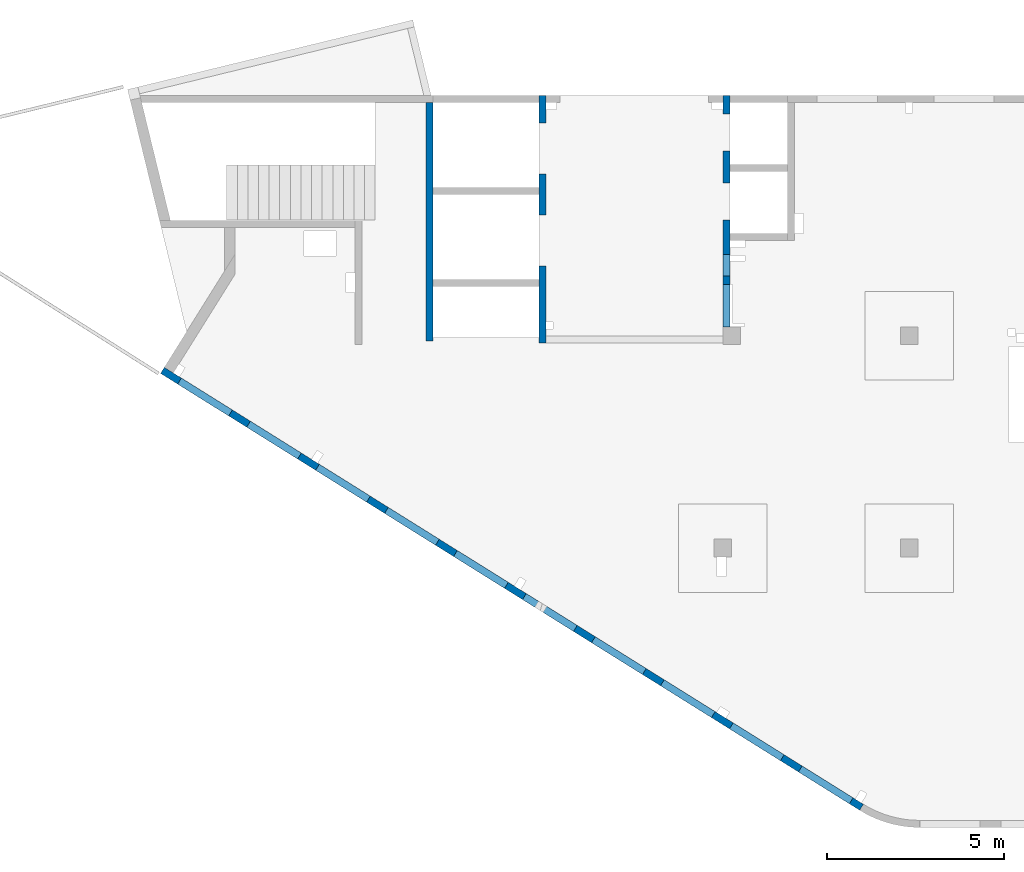
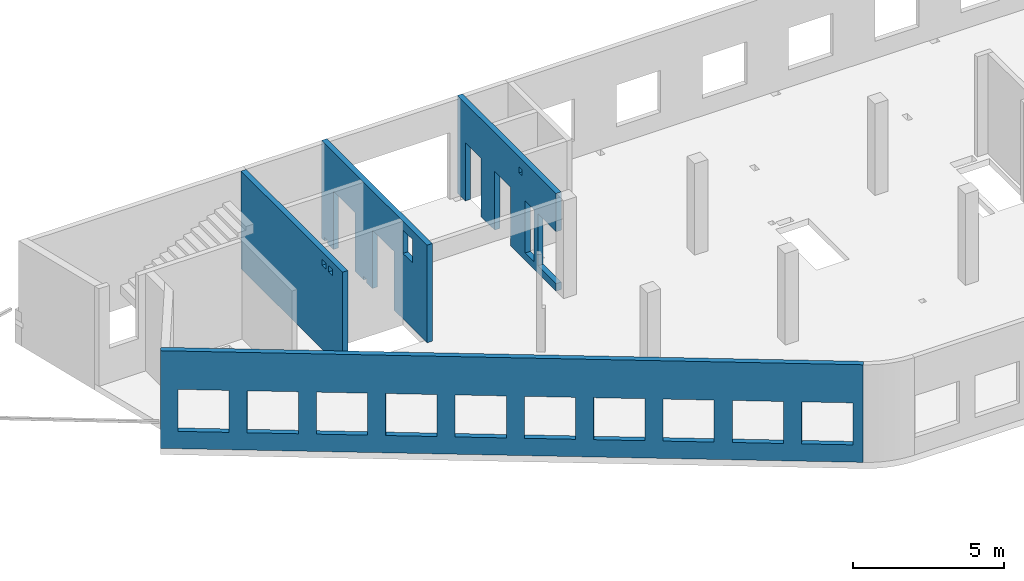
# One storey, part 5 of 7: 4 walls, 22 openings.
"""IFC4 building model written with IfcOpenShell, lengths in millimetres."""

from ifc_helpers import new_model, entity, si_unit, converted_unit, derived_unit, direction, frame, origin, place, context, subcontext, project, spatial, indexed_curve, outline, extrude, polygons, material, type_object, element, save


model = new_model("IFC4")

# Units and contexts
model_context = context("Model", 3, precision=0.01, world=origin(), true_north=direction((6.12303176911189e-17, 1.0)))
plan_context = context("Plan", 3, precision=0.01, world=origin(), true_north=direction((6.12303176911189e-17, 1.0)))
body_context = subcontext(model_context, "Body", "Model", "MODEL_VIEW")
ifc_project = project(units=[si_unit("LENGTHUNIT", "METRE", prefix="MILLI"), si_unit("AREAUNIT", "SQUARE_METRE"), si_unit("VOLUMEUNIT", "CUBIC_METRE"), converted_unit("PLANEANGLEUNIT", "DEGREE", entity("IfcRatioMeasure", 0.0174532925199433), si_unit("PLANEANGLEUNIT", "RADIAN"), dimensions=[0, 0, 0, 0, 0, 0, 0]), si_unit("MASSUNIT", "GRAM", prefix="KILO"), derived_unit("MASSDENSITYUNIT", [(si_unit("MASSUNIT", "GRAM", prefix="KILO"), 1), (si_unit("LENGTHUNIT", "METRE"), -3)]), derived_unit("MOMENTOFINERTIAUNIT", [(si_unit("LENGTHUNIT", "METRE"), 4)]), si_unit("TIMEUNIT", "SECOND"), si_unit("FREQUENCYUNIT", "HERTZ"), si_unit("THERMODYNAMICTEMPERATUREUNIT", "DEGREE_CELSIUS"), derived_unit("THERMALTRANSMITTANCEUNIT", [(si_unit("MASSUNIT", "GRAM", prefix="KILO"), 1), (si_unit("THERMODYNAMICTEMPERATUREUNIT", "KELVIN"), -1), (si_unit("TIMEUNIT", "SECOND"), -3)]), derived_unit("VOLUMETRICFLOWRATEUNIT", [(si_unit("LENGTHUNIT", "METRE"), 3), (si_unit("TIMEUNIT", "SECOND"), -1)]), derived_unit("MASSFLOWRATEUNIT", [(si_unit("MASSUNIT", "GRAM", prefix="KILO"), 1), (si_unit("TIMEUNIT", "SECOND"), -1)]), derived_unit("ROTATIONALFREQUENCYUNIT", [(si_unit("TIMEUNIT", "SECOND"), -1)]), si_unit("ELECTRICCURRENTUNIT", "AMPERE"), si_unit("ELECTRICVOLTAGEUNIT", "VOLT"), si_unit("POWERUNIT", "WATT"), si_unit("FORCEUNIT", "NEWTON", prefix="KILO"), si_unit("ILLUMINANCEUNIT", "LUX"), si_unit("LUMINOUSFLUXUNIT", "LUMEN"), si_unit("LUMINOUSINTENSITYUNIT", "CANDELA"), derived_unit("USERDEFINED", [(si_unit("MASSUNIT", "GRAM", prefix="KILO"), -1), (si_unit("LENGTHUNIT", "METRE"), -2), (si_unit("TIMEUNIT", "SECOND"), 3), (si_unit("LUMINOUSFLUXUNIT", "LUMEN"), 1)]), derived_unit("LINEARVELOCITYUNIT", [(si_unit("LENGTHUNIT", "METRE"), 1), (si_unit("TIMEUNIT", "SECOND"), -1)]), si_unit("PRESSUREUNIT", "PASCAL"), derived_unit("USERDEFINED", [(si_unit("LENGTHUNIT", "METRE"), -2), (si_unit("MASSUNIT", "GRAM", prefix="KILO"), 1), (si_unit("TIMEUNIT", "SECOND"), -2)]), derived_unit("LINEARFORCEUNIT", [(si_unit("MASSUNIT", "GRAM", prefix="KILO"), 1), (si_unit("LENGTHUNIT", "METRE"), 1), (si_unit("TIMEUNIT", "SECOND"), -2), (si_unit("LENGTHUNIT", "METRE"), -1)]), derived_unit("PLANARFORCEUNIT", [(si_unit("MASSUNIT", "GRAM", prefix="KILO"), 1), (si_unit("LENGTHUNIT", "METRE"), 1), (si_unit("TIMEUNIT", "SECOND"), -2), (si_unit("LENGTHUNIT", "METRE"), -2)])], contexts=[model_context, plan_context])

# Site, building, storey
site_placement = place(None, origin())
site = spatial("IfcSite", under=ifc_project, at=site_placement, CompositionType="ELEMENT")
building_placement = place(site_placement, origin())
building = spatial("IfcBuilding", under=site, at=building_placement, CompositionType="ELEMENT")
storey_placement = place(building_placement, frame((0.0, 0.0, 24000.0)))
storey = spatial("IfcBuildingStorey", under=building, at=storey_placement, Name="07", CompositionType="ELEMENT", Elevation=24000.0)

# Wall, openings
ifc_material = material()
wall_type = type_object("IfcWallType", Name=":ADSK_ 25_200", PredefinedType="STANDARD")
wall_1_placement = place(storey_placement, frame((19823.51, 370.44, -150.0), z_axis=(0.0, 0.0, 1.0), x_axis=(-0.848052743777574, 0.529911826412025, 0.0)))
wall_1 = element("IfcWall", 1, at=wall_1_placement, inside=storey, type_object=wall_type, material=ifc_material, Name=":ADSK_ 25_200", ObjectType=":ADSK_ 25_200", PredefinedType="NOTDEFINED", context=body_context, shape_type="Tessellation", body=[
    polygons([(-1.45510270499472e-12, -99.9999999999999, 0.0), (23013.0035862376, -99.9999999999989, 0.0), (23313.0035862376, -99.9999999999989, 0.0), (23313.0035862376, -99.9999999999989, 3950.0), (23013.0035862376, -99.9999999999989, 3950.0), (18403.0035862376, -99.9999999999989, 3950.0), (18103.0035862376, -100.0, 3950.0), (-1.45510270499472e-12, -99.9999999999999, 3950.0), (343.003167803934, -99.9999999999988, 2400.0), (2043.00316780393, -99.9999999999981, 2400.0), (2043.00316780393, -99.9999999999981, 700.00000000001), (343.003167803934, -99.9999999999988, 700.00000000001), (2643.00316780394, -99.9999999999995, 2400.0), (4343.00316780394, -99.9999999999992, 2400.0), (4343.00316780394, -99.9999999999992, 700.00000000001), (2643.00316780394, -99.9999999999995, 700.00000000001), (4943.00316780394, -100.0, 2400.0), (6643.00316780394, -99.9999999999984, 2400.0), (6643.00316780394, -99.9999999999984, 700.00000000001), (4943.00316780394, -100.0, 700.00000000001), (7243.00316780395, -99.9999999999984, 2400.0), (8943.00316780395, -100.0, 2400.0), (8943.00316780395, -100.0, 700.00000000001), (7243.00316780395, -99.9999999999984, 700.00000000001), (9543.00316780396, -100.0, 2400.0), (11243.003167804, -99.9999999999989, 2400.0), (11243.003167804, -99.9999999999989, 700.00000000001), (9543.00316780396, -100.0, 700.00000000001), (11843.003167804, -100.0, 2400.0), (13543.003167804, -100.0, 2400.0), (13543.003167804, -100.0, 700.00000000001), (11843.003167804, -100.0, 700.00000000001), (14143.003167804, -100.0, 2400.0), (15843.003167804, -100.0, 2400.0), (15843.003167804, -100.0, 700.00000000001), (14143.003167804, -100.0, 700.00000000001), (16443.003167804, -99.9999999999989, 2400.0), (18143.003167804, -99.9999999999989, 2400.0), (18143.003167804, -99.9999999999989, 700.00000000001), (16443.003167804, -99.9999999999989, 700.00000000001), (18743.003167804, -100.0, 2400.0), (20443.003167804, -99.9999999999989, 2400.0), (20443.003167804, -99.9999999999989, 700.00000000001), (18743.003167804, -100.0, 700.00000000001), (21043.003167804, -99.9999999999989, 2400.0), (22743.003167804, -100.000000000001, 2400.0), (22743.003167804, -100.000000000001, 700.00000000001), (21043.003167804, -99.9999999999989, 700.00000000001), (-2.21649365528265e-12, 100.000000000001, 0.0), (-2.18265405749207e-12, 100.000000000001, 3950.0), (1.38633244452641, 99.9999999999989, 3950.0), (23313.0035862376, 99.9999999999989, 3950.0), (23313.0035862376, 99.9999999999989, 0.0), (2043.00316780394, 100.000000000323, 2400.0), (343.003167803935, 100.000000000321, 2400.0), (343.003167803935, 100.000000000321, 700.00000000001), (2043.00316780394, 100.000000000323, 700.00000000001), (4343.00316780394, 100.000000000322, 2400.0), (2643.00316780394, 100.00000000032, 2400.0), (2643.00316780394, 100.00000000032, 700.00000000001), (4343.00316780394, 100.000000000322, 700.00000000001), (6643.00316780395, 100.000000000322, 2400.0), (4943.00316780394, 100.000000000321, 2400.0), (4943.00316780394, 100.000000000321, 700.00000000001), (6643.00316780395, 100.000000000322, 700.00000000001), (8943.00316780395, 100.000000000321, 2400.0), (7243.00316780395, 100.000000000322, 2400.0), (7243.00316780395, 100.000000000322, 700.00000000001), (8943.00316780395, 100.000000000321, 700.00000000001), (11243.003167804, 100.000000000323, 2400.0), (9543.00316780396, 100.000000000321, 2400.0), (9543.00316780396, 100.000000000321, 700.00000000001), (11243.003167804, 100.000000000323, 700.00000000001), (13543.003167804, 100.000000000319, 2400.0), (11843.003167804, 100.000000000323, 2400.0), (11843.003167804, 100.000000000323, 700.00000000001), (13543.003167804, 100.000000000319, 700.00000000001), (15843.003167804, 100.000000000322, 2400.0), (14143.003167804, 100.000000000322, 2400.0), (14143.003167804, 100.000000000322, 700.00000000001), (15843.003167804, 100.000000000322, 700.00000000001), (18143.003167804, 100.000000000322, 2400.0), (16443.003167804, 100.000000000322, 2400.0), (16443.003167804, 100.000000000322, 700.00000000001), (18143.003167804, 100.000000000322, 700.00000000001), (20443.003167804, 100.000000000322, 2400.0), (18743.003167804, 100.000000000319, 2400.0), (18743.003167804, 100.000000000319, 700.00000000001), (20443.003167804, 100.000000000322, 700.00000000001), (22743.003167804, 100.000000000319, 2400.0), (21043.003167804, 100.000000000321, 2400.0), (21043.003167804, 100.000000000323, 700.00000000001), (22743.003167804, 100.000000000319, 700.00000000001)], [[[1, 2, 3, 4, 5, 6, 7, 8], [9, 10, 11, 12], [13, 14, 15, 16], [17, 18, 19, 20], [21, 22, 23, 24], [25, 26, 27, 28], [29, 30, 31, 32], [33, 34, 35, 36], [37, 38, 39, 40], [41, 42, 43, 44], [45, 46, 47, 48]], [[49, 50, 51, 52, 53], [54, 55, 56, 57], [58, 59, 60, 61], [62, 63, 64, 65], [66, 67, 68, 69], [70, 71, 72, 73], [74, 75, 76, 77], [78, 79, 80, 81], [82, 83, 84, 85], [86, 87, 88, 89], [90, 91, 92, 93]], [[3, 2, 1, 49, 53]], [[8, 7, 6, 5, 4, 52, 51, 50]], [[1, 8, 50, 49]], [[4, 3, 53, 52]], [[55, 54, 10, 9]], [[55, 9, 12, 56]], [[56, 12, 11, 57]], [[10, 54, 57, 11]], [[59, 58, 14, 13]], [[59, 13, 16, 60]], [[60, 16, 15, 61]], [[14, 58, 61, 15]], [[63, 62, 18, 17]], [[63, 17, 20, 64]], [[64, 20, 19, 65]], [[18, 62, 65, 19]], [[67, 66, 22, 21]], [[67, 21, 24, 68]], [[68, 24, 23, 69]], [[22, 66, 69, 23]], [[71, 70, 26, 25]], [[71, 25, 28, 72]], [[72, 28, 27, 73]], [[26, 70, 73, 27]], [[75, 74, 30, 29]], [[75, 29, 32, 76]], [[76, 32, 31, 77]], [[30, 74, 77, 31]], [[79, 78, 34, 33]], [[79, 33, 36, 80]], [[80, 36, 35, 81]], [[34, 78, 81, 35]], [[83, 82, 38, 37]], [[83, 37, 40, 84]], [[84, 40, 39, 85]], [[38, 82, 85, 39]], [[87, 86, 42, 41]], [[87, 41, 44, 88]], [[88, 44, 43, 89]], [[42, 86, 89, 43]], [[91, 90, 46, 45]], [[91, 45, 48, 92]], [[92, 48, 47, 93]], [[46, 90, 93, 47]]], closed=True),
])
placement_1 = place(wall_1_placement, frame((16615.08, 10818.86, 150.0), z_axis=(0.0, 0.0, 1.0), x_axis=(-0.848052743777574, -0.529911826412026, 0.0)))
element("IfcOpeningElement", 2, at=placement_1, cuts=wall_1, Name=":ADSK_ 25_200", PredefinedType="OPENING", context=body_context, shape_type="SweptSolid", body=[
    extrude(outline(indexed_curve([(-849.999999999993, -850.0), (849.999999999993, -850.0), (849.999999999993, 850.0), (-849.999999999993, 850.0), (-849.999999999993, -850.0)], self_intersect=False)), frame((1310.08, 12056.6, 1400.0), z_axis=(-0.529911826412026, -0.848052743777574, 0.0), x_axis=(0.0, 0.0, -1.0)), (0.0, 0.0, 1.0), 200.000000000964),
])
element("IfcOpeningElement", 3, at=placement_1, cuts=wall_1, Name=":ADSK_ 25_200", PredefinedType="OPENING", context=body_context, shape_type="SweptSolid", body=[
    extrude(outline(indexed_curve([(-849.999999999993, -850.0), (849.999999999993, -850.0), (849.999999999993, 850.0), (-849.999999999993, 850.0), (-849.999999999993, -850.0)], self_intersect=False)), frame((3260.6, 10837.81, 1400.0), z_axis=(-0.529911826412026, -0.848052743777574, 0.0), x_axis=(0.0, 0.0, -1.0)), (0.0, 0.0, 1.0), 200.000000000964),
])
element("IfcOpeningElement", 4, at=placement_1, cuts=wall_1, Name=":ADSK_ 25_200", PredefinedType="OPENING", context=body_context, shape_type="SweptSolid", body=[
    extrude(outline(indexed_curve([(-849.999999999993, -850.0), (849.999999999993, -850.0), (849.999999999993, 850.0), (-849.999999999993, 850.0), (-849.999999999993, -850.0)], self_intersect=False)), frame((5211.12, 9619.01, 1400.0), z_axis=(-0.529911826412025, -0.848052743777574, 0.0), x_axis=(0.0, 0.0, -1.0)), (0.0, 0.0, 1.0), 200.000000000962),
])
element("IfcOpeningElement", 5, at=placement_1, cuts=wall_1, Name=":ADSK_ 25_200", PredefinedType="OPENING", context=body_context, shape_type="SweptSolid", body=[
    extrude(outline(indexed_curve([(-849.999999999993, -849.999999999999), (849.999999999993, -849.999999999999), (849.999999999993, 850.0), (-849.999999999993, 850.0), (-849.999999999993, -849.999999999999)], self_intersect=False)), frame((7161.64, 8400.21, 1400.0), z_axis=(-0.529911826412026, -0.848052743777574, 0.0), x_axis=(0.0, 0.0, -1.0)), (0.0, 0.0, 1.0), 200.000000000962),
])
element("IfcOpeningElement", 6, at=placement_1, cuts=wall_1, Name=":ADSK_ 25_200", PredefinedType="OPENING", context=body_context, shape_type="SweptSolid", body=[
    extrude(outline(indexed_curve([(-849.999999999993, -849.999999999999), (849.999999999993, -849.999999999999), (849.999999999993, 850.0), (-849.999999999993, 850.0), (-849.999999999993, -849.999999999999)], self_intersect=False)), frame((9112.16, 7181.41, 1400.0), z_axis=(-0.529911826412026, -0.848052743777574, 0.0), x_axis=(0.0, 0.0, -1.0)), (0.0, 0.0, 1.0), 200.000000000962),
])
element("IfcOpeningElement", 7, at=placement_1, cuts=wall_1, Name=":ADSK_ 25_200", PredefinedType="OPENING", context=body_context, shape_type="SweptSolid", body=[
    extrude(outline(indexed_curve([(-849.999999999993, -850.0), (849.999999999993, -850.0), (849.999999999993, 850.0), (-849.999999999993, 850.0), (-849.999999999993, -850.0)], self_intersect=False)), frame((11062.68, 5962.62, 1400.0), z_axis=(-0.529911826412025, -0.848052743777574, 0.0), x_axis=(0.0, 0.0, -1.0)), (0.0, 0.0, 1.0), 200.000000000964),
])
element("IfcOpeningElement", 8, at=placement_1, cuts=wall_1, Name=":ADSK_ 25_200", PredefinedType="OPENING", context=body_context, shape_type="SweptSolid", body=[
    extrude(outline(indexed_curve([(-849.999999999993, -850.0), (849.999999999993, -850.0), (849.999999999993, 850.0), (-849.999999999993, 850.0), (-849.999999999993, -850.0)], self_intersect=False)), frame((13013.21, 4743.82, 1400.0), z_axis=(-0.529911826412025, -0.848052743777574, 0.0), x_axis=(0.0, 0.0, -1.0)), (0.0, 0.0, 1.0), 200.000000000959),
])
element("IfcOpeningElement", 9, at=placement_1, cuts=wall_1, Name=":ADSK_ 25_200", PredefinedType="OPENING", context=body_context, shape_type="SweptSolid", body=[
    extrude(outline(indexed_curve([(-849.999999999993, -850.000000000002), (849.999999999993, -850.000000000002), (849.999999999993, 849.999999999998), (-849.999999999993, 849.999999999998), (-849.999999999993, -850.000000000002)], self_intersect=False)), frame((14963.73, 3525.02, 1400.0), z_axis=(-0.529911826412025, -0.848052743777574, 0.0), x_axis=(0.0, 0.0, -1.0)), (0.0, 0.0, 1.0), 200.000000000962),
])
element("IfcOpeningElement", 10, at=placement_1, cuts=wall_1, Name=":ADSK_ 25_200", PredefinedType="OPENING", context=body_context, shape_type="SweptSolid", body=[
    extrude(outline(indexed_curve([(-849.999999999993, -850.0), (849.999999999993, -850.0), (849.999999999993, 850.0), (-849.999999999993, 850.0), (-849.999999999993, -850.0)], self_intersect=False)), frame((16914.25, 2306.23, 1400.0), z_axis=(-0.529911826412025, -0.848052743777574, 0.0), x_axis=(0.0, 0.0, -1.0)), (0.0, 0.0, 1.0), 200.000000000962),
])
element("IfcOpeningElement", 11, at=placement_1, cuts=wall_1, Name=":ADSK_ 25_200", PredefinedType="OPENING", context=body_context, shape_type="SweptSolid", body=[
    extrude(outline(indexed_curve([(-849.999999999993, -850.0), (849.999999999993, -850.0), (849.999999999993, 850.0), (-849.999999999993, 850.0), (-849.999999999993, -850.0)], self_intersect=False)), frame((18864.77, 1087.43, 1400.0), z_axis=(-0.529911826412025, -0.848052743777574, 0.0), x_axis=(0.0, 0.0, -1.0)), (0.0, 0.0, 1.0), 200.000000000966),
])

wall_2_placement = place(storey_placement, frame((16000.0, 20500.0, -150.0), z_axis=(0.0, 0.0, 1.0), x_axis=(0.0, -1.0, 0.0)))
wall_2 = element("IfcWall", 12, at=wall_2_placement, inside=storey, type_object=wall_type, material=ifc_material, Name=":ADSK_ 25_200", ObjectType=":ADSK_ 25_200", PredefinedType="NOTDEFINED", context=body_context, shape_type="Tessellation", body=[
    polygons([(6550.00048980714, -99.9999999999982, 3950.0), (200.000000000002, -100.0, 3950.0), (0.0, -100.0, 3950.0), (0.0, -100.0, 0.0), (200.000000000002, -100.0, 0.0), (529.999999999996, -99.9999999999995, 0.0), (529.999999999996, -99.9999999999995, 2369.99999999805), (1570.0, -100.000000000002, 2369.99999999805), (1570.0, -100.000000000002, 0.0), (2480.0, -100.000000000001, 0.0), (2480.0, -100.000000000001, 2369.99999999805), (3519.99999999999, -100.000000000001, 2369.99999999805), (3519.99999999999, -100.000000000001, 0.0), (6550.00048980714, -99.9999999999982, 0.0), (6550.00048980714, -99.9999999999982, 300.000000000001), (5350.00048980714, -100.0, 300.000000000001), (5350.00048980714, -100.0, 2399.99999999998), (6550.00048980714, -99.9999999999982, 2399.99999999999), (4100.00063936683, -100.000000000321, 3549.99999999999), (4300.00063936683, -100.00000000032, 3549.99999999999), (4300.00063936683, -100.00000000032, 3300.00000000001), (4100.00063936683, -100.000000000321, 3300.00000000001), (4500.00063936683, -99.9999999999995, 2399.99999999999), (5100.00063936683, -100.000000000001, 2399.99999999999), (5100.00063936683, -100.000000000001, 300.000000000001), (4500.00063936683, -99.9999999999995, 300.000000000001), (4300.00063936683, 100.0, 3549.99999999999), (4100.00063936683, 99.9999999999999, 3549.99999999999), (4100.00063936683, 99.9999999999999, 3300.00000000001), (4300.00063936683, 100.0, 3300.00000000001), (5100.00063936683, 99.9999999999994, 2399.99999999999), (4500.00063936683, 99.9999999999984, 2399.99999999998), (4500.00063936683, 99.9999999999984, 300.000000000001), (5100.00063936683, 99.9999999999994, 300.000000000001), (0.0, 99.9999999999996, 3950.0), (200.000000000002, 99.9999999999999, 3950.0), (1950.0, 100.000000000001, 3950.0), (2150.0, 99.9999999999988, 3950.0), (3900.00063936683, 99.9999999999995, 3950.0), (4100.00063936683, 99.9999999999999, 3950.0), (6550.00048980714, 99.9999999999996, 3950.0), (6550.00048980714, 99.9999999999996, 2399.99999999999), (5350.00048980714, 99.9999999999998, 2399.99999999998), (5350.00048980714, 99.9999999999998, 300.000000000001), (6550.00048980714, 99.9999999999996, 300.000000000001), (6550.00048980714, 99.9999999999996, 0.0), (4100.00063936683, 99.9999999999999, 0.0), (3900.00063936683, 99.9999999999995, 0.0), (3519.99999999999, 99.9999999999989, 0.0), (3519.99999999999, 99.9999999999989, 2369.99999999805), (2480.0, 100.000000000002, 2369.99999999804), (2480.0, 100.000000000002, 0.0), (1570.0, 100.0, 0.0), (1570.0, 100.0, 2369.99999999805), (529.999999999996, 100.0, 2369.99999999804), (529.999999999996, 100.0, 0.0), (0.0, 99.9999999999996, 0.0)], [[[1, 2, 3, 4, 5, 6, 7, 8, 9, 10, 11, 12, 13, 14, 15, 16, 17, 18], [19, 20, 21, 22], [23, 24, 25, 26]], [[35, 36, 37, 38, 39, 40, 41, 42, 43, 44, 45, 46, 47, 48, 49, 50, 51, 52, 53, 54, 55, 56, 57], [27, 28, 29, 30], [31, 32, 33, 34]], [[4, 57, 56, 6, 5]], [[14, 46, 45, 15]], [[3, 2, 1, 41, 40, 39, 38, 37, 36, 35]], [[4, 3, 35, 57]], [[20, 19, 28, 27]], [[20, 27, 30, 21]], [[21, 30, 29, 22]], [[28, 19, 22, 29]], [[31, 24, 23, 32]], [[32, 23, 26, 33]], [[33, 26, 25, 34]], [[24, 31, 34, 25]], [[17, 43, 42, 18]], [[43, 17, 16, 44]], [[44, 16, 15, 45]], [[50, 12, 11, 51]], [[51, 11, 10, 52]], [[12, 50, 49, 13]], [[54, 8, 7, 55]], [[55, 7, 6, 56]], [[8, 54, 53, 9]], [[41, 1, 18, 42]], [[52, 10, 9, 53]], [[46, 14, 13, 49, 48, 47]]], closed=True),
])
placement_2 = place(wall_2_placement, frame((20500.0, -16000.0, 150.0), z_axis=(0.0, 0.0, 1.0), x_axis=(0.0, 1.0, 0.0)))
element("IfcOpeningElement", 13, at=placement_2, cuts=wall_2, Name=":ADSK_ 25_200", PredefinedType="OPENING", context=body_context, shape_type="SweptSolid", body=[
    extrude(outline(indexed_curve([(-1049.99999999999, -600.0), (1050.0, -600.0), (1050.0, 600.0), (-1049.99999999999, 600.0), (-1049.99999999999, -600.0)], self_intersect=False)), frame((15800.0, 14550.0, 1200.0), z_axis=(1.0, 0.0, 0.0), x_axis=(0.0, 0.0, -1.0)), (0.0, 0.0, 1.0), 400.000000001943),
])
element("IfcOpeningElement", 14, at=placement_2, cuts=wall_2, Name=":ADSK_ 25_200", PredefinedType="OPENING", context=body_context, shape_type="SweptSolid", body=[
    extrude(outline(indexed_curve([(-1184.99999999902, -520.000000000001), (1184.99999999902, -520.000000000001), (1184.99999999902, 519.999999999999), (-1184.99999999902, 519.999999999999), (-1184.99999999902, -520.000000000001)], self_intersect=False)), frame((15800.0, 17500.0, 1035.0), z_axis=(1.0, 0.0, 0.0), x_axis=(0.0, 0.0, -1.0)), (0.0, 0.0, 1.0), 400.000000001943),
])
element("IfcOpeningElement", 15, at=placement_2, cuts=wall_2, Name=":ADSK_ 25_200", PredefinedType="OPENING", context=body_context, shape_type="SweptSolid", body=[
    extrude(outline(indexed_curve([(-1184.99999999902, -519.999999999999), (1184.99999999902, -519.999999999999), (1184.99999999902, 520.000000000001), (-1184.99999999902, 520.000000000001), (-1184.99999999902, -519.999999999999)], self_intersect=False)), frame((15800.0, 19450.0, 1035.0), z_axis=(1.0, 0.0, 0.0), x_axis=(0.0, 0.0, -1.0)), (0.0, 0.0, 1.0), 400.000000001943),
])
element("IfcOpeningElement", 16, at=placement_2, cuts=wall_2, Name=":ADSK_ 25_200", PredefinedType="OPENING", context=body_context, shape_type="SweptSolid", body=[
    extrude(outline(indexed_curve([(-100.000000000001, -124.999999999993), (99.9999999999989, -124.999999999993), (99.9999999999989, 124.999999999993), (-100.000000000001, 124.999999999993), (-100.000000000001, -124.999999999993)], self_intersect=False)), frame((15900.0, 16300.0, 3275.0), z_axis=(1.0, 0.0, 0.0), x_axis=(0.0, -1.0, 0.0)), (0.0, 0.0, 1.0), 200.000000000962),
])
element("IfcOpeningElement", 17, at=placement_2, cuts=wall_2, Name=":ADSK_ 25_200", PredefinedType="OPENING", context=body_context, shape_type="SweptSolid", body=[
    extrude(outline(indexed_curve([(-1049.99999999999, -300.000000000001), (1050.0, -300.000000000001), (1050.0, 299.999999999999), (-1049.99999999999, 299.999999999999), (-1049.99999999999, -300.000000000001)], self_intersect=False)), frame((15800.0, 15700.0, 1200.0), z_axis=(1.0, 0.0, 0.0), x_axis=(0.0, 0.0, -1.0)), (0.0, 0.0, 1.0), 400.000000001943),
])

wall_3_placement = place(storey_placement, frame((7600.0, 20300.0, -150.0), z_axis=(0.0, 0.0, 1.0), x_axis=(0.0, -1.0, 0.0)))
wall_3 = element("IfcWall", 18, at=wall_3_placement, inside=storey, type_object=wall_type, material=ifc_material, Name=":ADSK_ 25_200", ObjectType=":ADSK_ 25_200", PredefinedType="NOTDEFINED", context=body_context, shape_type="Tessellation", body=[
    polygons([(0.0, -100.000000000001, 0.0), (6750.0006393668, -99.9999999999998, 0.0), (6750.0006393668, -99.9999999999998, 3950.0), (0.0, -100.000000000001, 3950.0), (5815.0, -100.0, 3400.00000000001), (5815.0, -100.0, 3650.0), (6065.0, -99.9999999999998, 3650.0), (6065.0, -99.9999999999998, 3400.00000000001), (5375.0, -100.000000000001, 3650.0), (5625.0, -100.0, 3650.0), (5625.0, -100.0, 3400.00000000001), (5375.0, -100.000000000001, 3400.00000000001), (5815.0, 100.000000000321, 3650.0), (5815.0, 100.000000000321, 3400.00000000001), (6065.0, 100.000000000321, 3400.00000000001), (6065.0, 100.000000000321, 3650.0), (6750.0006393668, 99.9999999999992, 0.0), (6650.00063936679, 100.0, 0.0), (0.0, 100.0, 0.0), (0.0, 100.0, 499.999999999999), (0.0, 100.0, 700.000000000001), (0.0, 100.0, 3950.0), (2400.0, 99.9999999999999, 3950.0), (2600.0, 100.0, 3950.0), (5000.0, 100.000000000001, 3950.0), (5200.0, 100.0, 3950.0), (6600.0, 100.0, 3950.0), (6750.0006393668, 99.9999999999992, 3950.0), (5625.0, 100.000000000321, 3650.0), (5375.0, 100.000000000321, 3650.0), (5375.0, 100.000000000321, 3400.00000000001), (5625.0, 100.000000000321, 3400.00000000001)], [[[1, 2, 3, 4], [5, 6, 7, 8], [9, 10, 11, 12]], [[17, 18, 19, 20, 21, 22, 23, 24, 25, 26, 27, 28], [13, 14, 15, 16], [29, 30, 31, 32]], [[2, 1, 19, 18, 17]], [[3, 2, 17, 28]], [[4, 3, 28, 27, 26, 25, 24, 23, 22]], [[6, 13, 16, 7]], [[13, 6, 5, 14]], [[14, 5, 8, 15]], [[7, 16, 15, 8]], [[9, 30, 29, 10]], [[30, 9, 12, 31]], [[31, 12, 11, 32]], [[10, 29, 32, 11]], [[4, 22, 21, 20, 19, 1]]], closed=True),
])
placement_3 = place(wall_3_placement, frame((20300.0, -7600.0, 150.0), z_axis=(0.0, 0.0, 1.0), x_axis=(0.0, 1.0, 0.0)))
element("IfcOpeningElement", 19, at=placement_3, cuts=wall_3, Name=":ADSK_ 25_200", PredefinedType="OPENING", context=body_context, shape_type="SweptSolid", body=[
    extrude(outline(indexed_curve([(-124.999999999993, -125.0), (124.999999999993, -125.0), (124.999999999993, 125.0), (-124.999999999993, 125.0), (-124.999999999993, -125.0)], self_intersect=False)), frame((7500.0, 14800.0, 3375.0), z_axis=(1.0, 0.0, 0.0), x_axis=(0.0, 0.0, -1.0)), (0.0, 0.0, 1.0), 200.000000000962),
])
element("IfcOpeningElement", 20, at=placement_3, cuts=wall_3, Name=":ADSK_ 25_200", PredefinedType="OPENING", context=body_context, shape_type="SweptSolid", body=[
    extrude(outline(indexed_curve([(-124.999999999993, -125.0), (124.999999999993, -125.0), (124.999999999993, 125.0), (-124.999999999993, 125.0), (-124.999999999993, -125.0)], self_intersect=False)), frame((7500.0, 14360.0, 3375.0), z_axis=(1.0, 0.0, 0.0), x_axis=(0.0, 0.0, -1.0)), (0.0, 0.0, 1.0), 200.000000000962),
])

wall_4_placement = place(storey_placement, frame((10800.0, 20500.0, -150.0), z_axis=(0.0, 0.0, 1.0), x_axis=(0.0, -1.0, 0.0)))
wall_4 = element("IfcWall", 21, at=wall_4_placement, inside=storey, type_object=wall_type, material=ifc_material, Name=":ADSK_ 25_200", ObjectType=":ADSK_ 25_200", PredefinedType="NOTDEFINED", context=body_context, shape_type="Tessellation", body=[
    polygons([(5400.00000000002, -99.999999999999, 3600.0), (6050.00000000002, -99.9999999999979, 3600.0), (6050.00000000002, -99.9999999999979, 2650.00000000002), (5400.00000000002, -99.999999999999, 2650.00000000002), (7000.0006393668, -99.9999999999986, 3950.0), (6800.00000000001, -99.9999999999989, 3950.0), (5400.00000000002, -99.999999999999, 3950.0), (5200.00000000002, -99.9999999999993, 3950.0), (2800.00000000002, -99.9999999999987, 3950.0), (2600.00000000002, -99.9999999999991, 3950.0), (200.000000000028, -99.9999999999985, 3950.0), (0.0, -99.9999999999988, 3950.0), (0.0, -99.9999999999988, 0.0), (200.000639366303, -99.9999999999985, 0.0), (200.000639366303, -99.9999999999985, 149.999999999975), (400.000639366301, -99.9999999999982, 149.999999999975), (400.000639366301, -99.9999999999982, 0.0), (780.000000000018, -99.9999999999976, 0.0), (780.000000000018, -99.9999999999976, 2369.99999999805), (2220.00000000001, -99.9999999999975, 2369.99999999804), (2220.00000000001, -99.9999999999997, 0.0), (2800.00000000003, -99.9999999999987, 0.0), (2800.00000000003, -99.9999999999987, 149.999999999983), (3000.00000000003, -99.9999999999984, 149.999999999983), (3000.00000000003, -99.9999999999984, 0.0), (3380.00000000002, -99.9999999999978, 0.0), (3380.00000000002, -99.9999999999978, 2369.99999999805), (4820.00000000001, -99.9999999999977, 2369.99999999804), (4820.00000000001, -99.9999999999977, 0.0), (6850.00063936681, -99.9999999999988, 0.0), (7000.0006393668, -99.9999999999986, 0.0), (0.0, 100.000000000001, 3950.0), (200.000000000002, 100.000000000001, 3950.0), (6800.0006393668, 100.000000000001, 3950.0), (7000.0006393668, 100.000000000001, 3950.0), (7000.0006393668, 100.000000000001, 3200.0), (7000.0006393668, 100.000000000001, 0.0), (6600.0006393668, 100.000000000001, 0.0), (6400.0006393668, 100.0, 0.0), (4820.00000000001, 100.000000000002, 0.0), (4820.00000000002, 100.000000000002, 2369.99999999805), (3380.00000000002, 100.000000000002, 2369.99999999804), (3380.00000000002, 100.000000000002, 0.0), (3000.00000000003, 100.000000000002, 0.0), (3000.00000000003, 100.000000000322, 149.999999999983), (2800.00000000003, 100.000000000322, 149.999999999983), (2800.00000000003, 100.000000000001, 0.0), (2220.00000000001, 100.000000000003, 0.0), (2220.00000000001, 100.000000000003, 2369.99999999804), (780.000000000018, 100.000000000002, 2369.99999999805), (780.000000000018, 100.000000000002, 0.0), (400.000639366301, 100.000000000002, 0.0), (400.000639366301, 100.000000000322, 149.999999999975), (200.000639366303, 100.000000000322, 149.999999999975), (200.000639366303, 100.000000000001, 0.0), (0.0, 100.000000000001, 0.0), (6050.00000000002, 100.000000000323, 3600.0), (5400.00000000002, 100.000000000322, 3600.0), (5400.00000000002, 100.000000000322, 2650.00000000002), (6050.00000000002, 100.000000000323, 2650.00000000002)], [[[5, 6, 7, 8, 9, 10, 11, 12, 13, 14, 15, 16, 17, 18, 19, 20, 21, 22, 23, 24, 25, 26, 27, 28, 29, 30, 31], [1, 2, 3, 4]], [[32, 33, 34, 35, 36, 37, 38, 39, 40, 41, 42, 43, 44, 45, 46, 47, 48, 49, 50, 51, 52, 53, 54, 55, 56], [57, 58, 59, 60]], [[13, 56, 55, 14]], [[12, 11, 10, 9, 8, 7, 6, 5, 35, 34, 33, 32]], [[13, 12, 32, 56]], [[58, 57, 2, 1]], [[58, 1, 4, 59]], [[59, 4, 3, 60]], [[2, 57, 60, 3]], [[19, 50, 49, 20]], [[20, 49, 48, 21]], [[50, 19, 18, 51]], [[41, 28, 27, 42]], [[42, 27, 26, 43]], [[28, 41, 40, 29]], [[5, 31, 37, 36, 35]], [[15, 54, 53, 16]], [[54, 15, 14, 55]], [[16, 53, 52, 17]], [[23, 46, 45, 24]], [[46, 23, 22, 47]], [[24, 45, 44, 25]], [[21, 48, 47, 22]], [[31, 30, 29, 40, 39, 38, 37]], [[43, 26, 25, 44]], [[51, 18, 17, 52]]], closed=True),
])
placement_4 = place(wall_4_placement, frame((20500.0, -10800.0, 150.0), z_axis=(0.0, 0.0, 1.0), x_axis=(0.0, 1.0, 0.0)))
element("IfcOpeningElement", 22, at=placement_4, cuts=wall_4, Name=":ADSK_ 25_200", PredefinedType="OPENING", context=body_context, shape_type="SweptSolid", body=[
    extrude(outline(indexed_curve([(-719.999999999999, -1184.99999999902), (719.999999999999, -1184.99999999902), (719.999999999999, 1184.99999999902), (-719.999999999999, 1184.99999999902), (-719.999999999999, -1184.99999999902)], self_intersect=False)), frame((10600.0, 19000.0, 1035.0), z_axis=(1.0, 0.0, 0.0), x_axis=(0.0, -1.0, 0.0)), (0.0, 0.0, 1.0), 400.000000001943),
])
element("IfcOpeningElement", 23, at=placement_4, cuts=wall_4, Name=":ADSK_ 25_200", PredefinedType="OPENING", context=body_context, shape_type="SweptSolid", body=[
    extrude(outline(indexed_curve([(-1184.99999999902, -719.999999999999), (1184.99999999902, -719.999999999999), (1184.99999999902, 720.000000000001), (-1184.99999999902, 720.000000000001), (-1184.99999999902, -719.999999999999)], self_intersect=False)), frame((10600.0, 16400.0, 1035.0), z_axis=(1.0, 0.0, 0.0), x_axis=(0.0, 0.0, -1.0)), (0.0, 0.0, 1.0), 400.000000001943),
])
element("IfcOpeningElement", 24, at=placement_4, cuts=wall_4, Name=":ADSK_ 25_200", PredefinedType="OPENING", context=body_context, shape_type="SweptSolid", body=[
    extrude(outline(indexed_curve([(-74.9999999999916, -99.9999999999989), (74.9999999999916, -99.9999999999989), (74.9999999999916, 99.9999999999989), (-74.9999999999916, 99.9999999999989), (-74.9999999999916, -99.9999999999989)], self_intersect=False)), frame((10700.0, 20200.0, -75.0), z_axis=(1.0, 0.0, 0.0), x_axis=(0.0, 0.0, -1.0)), (0.0, 0.0, 1.0), 200.000000000962),
])
element("IfcOpeningElement", 25, at=placement_4, cuts=wall_4, Name=":ADSK_ 25_200", PredefinedType="OPENING", context=body_context, shape_type="SweptSolid", body=[
    extrude(outline(indexed_curve([(-74.9999999999916, -100.000000000001), (74.9999999999916, -100.000000000001), (74.9999999999916, 99.9999999999989), (-74.9999999999916, 99.9999999999989), (-74.9999999999916, -100.000000000001)], self_intersect=False)), frame((10700.0, 17600.0, -75.0), z_axis=(1.0, 0.0, 0.0), x_axis=(0.0, 0.0, -1.0)), (0.0, 0.0, 1.0), 200.000000000962),
])
element("IfcOpeningElement", 26, at=placement_4, cuts=wall_4, Name=":ADSK_ 25_200", PredefinedType="OPENING", context=body_context, shape_type="SweptSolid", body=[
    extrude(outline(indexed_curve([(-474.999999999996, -325.0), (474.999999999992, -325.0), (474.999999999992, 325.0), (-474.999999999996, 325.0), (-474.999999999996, -325.0)], self_intersect=False)), frame((10700.0, 14775.0, 2975.0), z_axis=(1.0, 0.0, 0.0), x_axis=(0.0, 0.0, -1.0)), (0.0, 0.0, 1.0), 200.000000000962),
])

save(model, "model.ifc")
